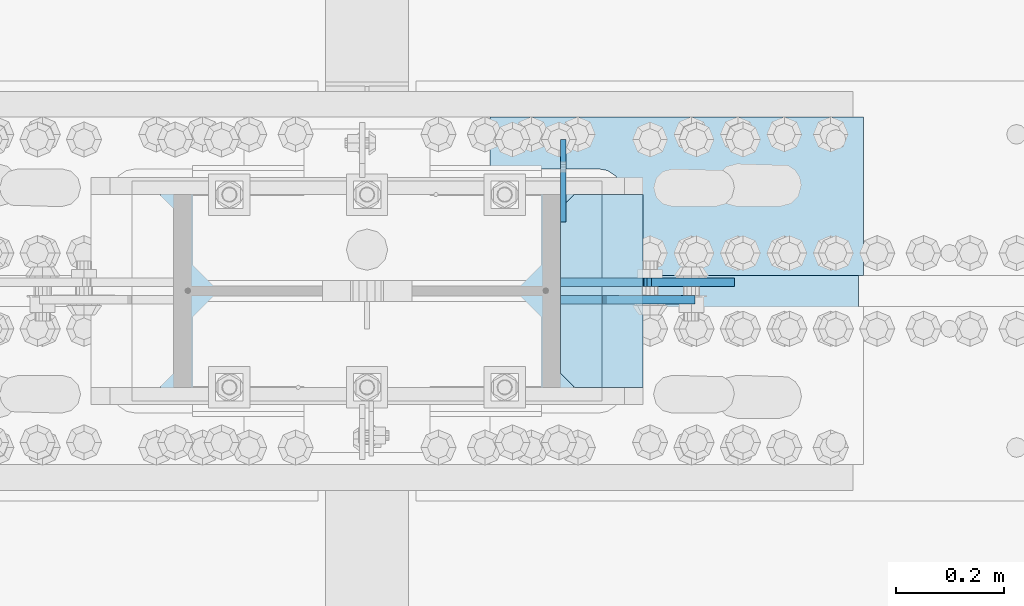
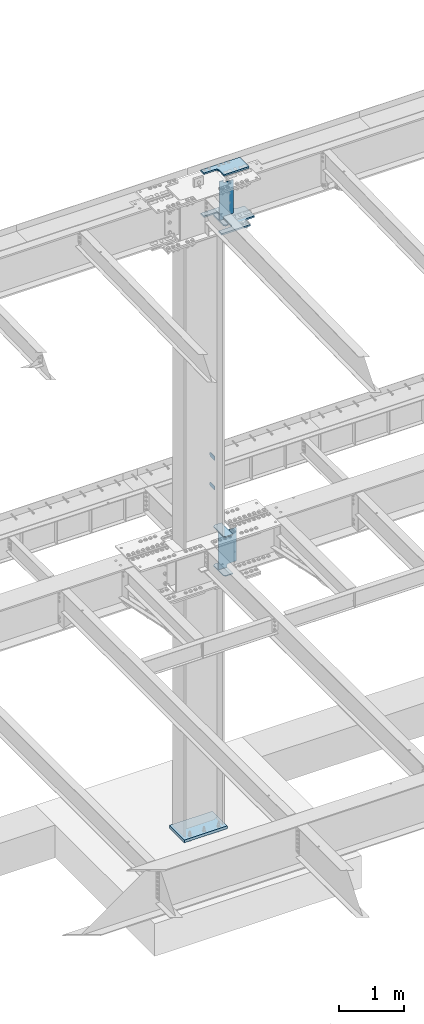
# One storey, part 1609 of 1763: 10 plates, 3 elements without a shape of their own.
"""IFC2X3 building model written with IfcOpenShell, lengths in millimetres."""

from ifc_helpers import new_model, si_unit, frame, origin_with_axes, place, context, subcontext, project, spatial, faceted_brep, material, type_object, element, aggregate, save


model = new_model("IFC2X3")

# Units and contexts
model_context = context("Model", 3, precision=1e-05, world=origin_with_axes())
body_context = subcontext(model_context, "Body", "Model", "MODEL_VIEW")
ifc_project = project(units=[si_unit("LENGTHUNIT", "METRE", prefix="MILLI"), si_unit("AREAUNIT", "SQUARE_METRE"), si_unit("VOLUMEUNIT", "CUBIC_METRE"), si_unit("MASSUNIT", "GRAM", prefix="KILO"), si_unit("TIMEUNIT", "SECOND"), si_unit("PLANEANGLEUNIT", "RADIAN"), si_unit("SOLIDANGLEUNIT", "STERADIAN"), si_unit("THERMODYNAMICTEMPERATUREUNIT", "DEGREE_CELSIUS"), si_unit("LUMINOUSINTENSITYUNIT", "LUMEN")], contexts=[model_context])

# Site, building, storey
site_placement = place(None, origin_with_axes())
site = spatial("IfcSite", under=ifc_project, at=site_placement, CompositionType="ELEMENT")
building_placement = place(site_placement, origin_with_axes())
building = spatial("IfcBuilding", under=site, at=building_placement, Name="Undefined", CompositionType="ELEMENT")
storey_placement = place(building_placement, origin_with_axes())
storey = spatial("IfcBuildingStorey", under=building, at=storey_placement, Name="Undefined", CompositionType="ELEMENT", Elevation=0.0)

# Assembly, plates
assembly_1_placement = place(storey_placement, origin_with_axes())
assembly_1 = element("IfcElementAssembly", 1, at=assembly_1_placement, inside=storey, Name="COLUMN", AssemblyPlace="NOTDEFINED", PredefinedType="RIGID_FRAME")
ifc_material_1 = material(Name="STEEL/A36")
plate_type_1 = type_object("IfcPlateType", PredefinedType="NOTDEFINED")
plate_1_placement = place(assembly_1_placement, frame((-72129.0872736984, 52247.8, 6489.69999847412), z_axis=(0.0, 0.0, -1.0), x_axis=(0.0, 1.0, 0.0)))
plate_1 = element("IfcPlate", 2, at=plate_1_placement, type_object=plate_type_1, material=ifc_material_1, Name="PLATE", context=body_context, shape_type="Brep", body=[
    faceted_brep([(0.0, -4.76249999999982, 0.0), (0.0, -4.76250000000073, 76.1999969482422), (0.0, 4.76250000000073, 76.1999969482422), (0.0, 4.76249999999982, 0.0), (114.299995422363, -4.76250000000073, 76.1999969482422), (114.299995422363, 4.76250000000073, 76.1999969482422), (126.073542436527, -4.76250000000073, 74.3352502937696), (126.073542436527, 4.76250000000073, 74.3352502937696), (136.694612637817, -4.76250000000073, 68.923544725345), (136.694612637817, 4.76250000000073, 68.923544725345), (145.123541673587, -4.76250000000073, 60.4946156895749), (145.123541673587, 4.76250000000073, 60.4946156895749), (150.535247242013, -4.76250000000073, 49.8735454882844), (150.535247242013, 4.76250000000073, 49.8735454882844), (152.399993896484, -4.76250000000073, 38.0999984741211), (152.399993896484, 4.76250000000073, 38.0999984741211), (150.535247242013, -4.76250000000073, 26.3264514599578), (150.535247242013, 4.76250000000073, 26.3264514599578), (145.123541673587, -4.76250000000073, 15.7053812586673), (145.123541673587, 4.76250000000073, 15.7053812586673), (136.694612637817, -4.76250000000073, 7.27645222289721), (136.694612637817, 4.76250000000073, 7.27645222289721), (126.073542436527, -4.76250000000073, 1.86474665447258), (126.073542436527, 4.76250000000073, 1.86474665447258), (114.299995422363, -4.76250000000073, 0.0), (114.299995422363, 4.76250000000073, 0.0)], [[[0, 1, 2, 3]], [[1, 4, 5, 2]], [[4, 6, 7, 5]], [[6, 8, 9, 7]], [[8, 10, 11, 9]], [[10, 12, 13, 11]], [[12, 14, 15, 13]], [[14, 16, 17, 15]], [[16, 18, 19, 17]], [[18, 20, 21, 19]], [[20, 22, 23, 21]], [[22, 24, 25, 23]], [[24, 0, 3, 25]], [[5, 7, 9, 11, 13, 15, 17, 19, 21, 23, 25, 3, 2]], [[24, 22, 20, 18, 16, 14, 12, 10, 8, 6, 4, 1, 0]]]),
])
plate_2_placement = place(assembly_1_placement, frame((-72129.0872736984, 52247.8, 5930.89999847412), z_axis=(0.0, 0.0, -1.0), x_axis=(0.0, 1.0, 0.0)))
plate_2 = element("IfcPlate", 3, at=plate_2_placement, type_object=plate_type_1, material=ifc_material_1, Name="PLATE", context=body_context, shape_type="Brep", body=[
    faceted_brep([(0.0, -4.76249999999982, 0.0), (0.0, -4.76250000000073, 76.1999969482422), (0.0, 4.76250000000073, 76.1999969482422), (0.0, 4.76249999999982, 0.0), (114.299995422363, -4.76250000000073, 76.1999969482422), (114.299995422363, 4.76250000000073, 76.1999969482422), (126.073542436527, -4.76250000000073, 74.3352502937696), (126.073542436527, 4.76250000000073, 74.3352502937696), (136.694612637817, -4.76250000000073, 68.923544725345), (136.694612637817, 4.76250000000073, 68.923544725345), (145.123541673587, -4.76250000000073, 60.4946156895749), (145.123541673587, 4.76250000000073, 60.4946156895749), (150.535247242013, -4.76250000000073, 49.8735454882844), (150.535247242013, 4.76250000000073, 49.8735454882844), (152.399993896484, -4.76250000000073, 38.0999984741211), (152.399993896484, 4.76250000000073, 38.0999984741211), (150.535247242013, -4.76250000000073, 26.3264514599578), (150.535247242013, 4.76250000000073, 26.3264514599578), (145.123541673587, -4.76250000000073, 15.7053812586673), (145.123541673587, 4.76250000000073, 15.7053812586673), (136.694612637817, -4.76250000000073, 7.27645222289721), (136.694612637817, 4.76250000000073, 7.27645222289721), (126.073542436527, -4.76250000000073, 1.86474665447258), (126.073542436527, 4.76250000000073, 1.86474665447258), (114.299995422363, -4.76250000000073, 0.0), (114.299995422363, 4.76250000000073, 0.0)], [[[0, 1, 2, 3]], [[1, 4, 5, 2]], [[4, 6, 7, 5]], [[6, 8, 9, 7]], [[8, 10, 11, 9]], [[10, 12, 13, 11]], [[12, 14, 15, 13]], [[14, 16, 17, 15]], [[16, 18, 19, 17]], [[18, 20, 21, 19]], [[20, 22, 23, 21]], [[22, 24, 25, 23]], [[24, 0, 3, 25]], [[5, 7, 9, 11, 13, 15, 17, 19, 21, 23, 25, 3, 2]], [[24, 22, 20, 18, 16, 14, 12, 10, 8, 6, 4, 1, 0]]]),
])
ifc_material_2 = material(Name="STEEL/A572-50")
plate_type_2 = type_object("IfcPlateType", PredefinedType="NOTDEFINED")
plate_3_placement = place(assembly_1_placement, frame((-71981.4497798019, 52298.6, 5157.7875), z_axis=(-1.0, 0.0, 0.0), x_axis=(0.0, -1.0, 0.0)))
plate_3 = element("IfcPlate", 4, at=plate_3_placement, type_object=plate_type_2, material=ifc_material_2, Name="PLATE", context=body_context, shape_type="Brep", body=[
    faceted_brep([(-7.27595761418343e-12, -7.9375, 0.0), (0.0, -7.9375, 126.999994277954), (0.0, 7.9375, 126.999994277954), (-7.27595761418343e-12, 7.9375, 0.0), (25.3999996185303, -7.9375, 152.399993896484), (25.3999996185303, 7.9375, 152.399993896484), (330.200006484985, -7.9375, 152.399993896484), (330.200006484985, 7.9375, 152.399993896484), (355.600006103516, -7.9375, 126.999994277954), (355.600006103516, 7.9375, 126.999994277954), (355.600006103516, -7.9375, 0.0), (355.600006103516, 7.9375, 0.0)], [[[0, 1, 2, 3]], [[1, 4, 5, 2]], [[4, 6, 7, 5]], [[6, 8, 9, 7]], [[8, 10, 11, 9]], [[10, 0, 3, 11]], [[5, 7, 9, 11, 3, 2]], [[10, 8, 6, 4, 1, 0]]]),
])
plate_4_placement = place(assembly_1_placement, frame((-71981.4497798019, 52298.6, 4427.5375), z_axis=(-1.0, 0.0, 0.0), x_axis=(0.0, -1.0, 0.0)))
plate_4 = element("IfcPlate", 5, at=plate_4_placement, type_object=plate_type_2, material=ifc_material_2, Name="PLATE", context=body_context, shape_type="Brep", body=[
    faceted_brep([(-7.27595761418343e-12, -7.9375, 0.0), (0.0, -7.9375, 126.999994277954), (0.0, 7.9375, 126.999994277954), (-7.27595761418343e-12, 7.9375, 0.0), (25.3999996185303, -7.9375, 152.399993896484), (25.3999996185303, 7.9375, 152.399993896484), (330.200006484985, -7.9375, 152.399993896484), (330.200006484985, 7.9375, 152.399993896484), (355.600006103516, -7.9375, 126.999994277954), (355.600006103516, 7.9375, 126.999994277954), (355.600006103516, -7.9375, 0.0), (355.600006103516, 7.9375, 0.0)], [[[0, 1, 2, 3]], [[1, 4, 5, 2]], [[4, 6, 7, 5]], [[6, 8, 9, 7]], [[8, 10, 11, 9]], [[10, 0, 3, 11]], [[5, 7, 9, 11, 3, 2]], [[10, 8, 6, 4, 1, 0]]]),
])

# Assembly, plate
assembly_2_placement = place(storey_placement, origin_with_axes())
assembly_2 = element("IfcElementAssembly", 6, at=assembly_2_placement, inside=storey, Name="PLATE", AssemblyPlace="NOTDEFINED", PredefinedType="RIGID_FRAME")
plate_type_3 = type_object("IfcPlateType", PredefinedType="NOTDEFINED")
plate_5_placement = place(assembly_2_placement, frame((-72264.0247736983, 51800.1250002128, 10955.3374917654), z_axis=(0.0, 1.0, 0.0), x_axis=(1.0, 0.0, 0.0)))
plate_5 = element("IfcPlate", 7, at=plate_5_placement, type_object=plate_type_3, material=ifc_material_2, Name="PLATE", context=body_context, shape_type="Brep", body=[
    faceted_brep([(0.0, -14.2875000000058, 0.0), (0.0, -14.2875000000004, 95.25), (0.0, 14.2875000000004, 95.25), (0.0, 14.2875000000058, 0.0), (209.550006866455, -14.2875000000004, 95.25), (209.550006866455, 14.2875000000004, 95.25), (220.342425159237, -14.2875000000004, 96.9593511310522), (220.342425159237, 14.2875000000004, 96.9593511310522), (230.078406354325, -14.2875000000004, 101.920081325748), (230.078406354325, 14.2875000000004, 101.920081325748), (237.804924777767, -14.2875000000004, 109.646599749191), (237.804924777767, 14.2875000000004, 109.646599749191), (242.765654972463, -14.2875000000004, 119.382580944279), (242.765654972463, 14.2875000000004, 119.382580944279), (244.475006103516, -14.2875000000004, 130.174999237061), (244.475006103516, 14.2875000000004, 130.174999237061), (244.475006103516, -14.2875000000004, 511.174976348877), (244.475006103516, 14.2875000000004, 511.174976348877), (242.765654972463, -14.2875000000004, 521.967394641659), (242.765654972463, 14.2875000000004, 521.967394641659), (237.804924777767, -14.2875000000004, 531.703375836747), (237.804924777767, 14.2875000000004, 531.703375836747), (230.078406354325, -14.2875000000004, 539.429894260189), (230.078406354325, 14.2875000000004, 539.429894260189), (220.342425159237, -14.2875000000004, 544.390624454885), (220.342425159237, 14.2875000000004, 544.390624454885), (209.550006866455, -14.2875000000004, 546.099975585938), (209.550006866455, 14.2875000000004, 546.099975585938), (0.0, -14.2875000000004, 546.099975585938), (0.0, 14.2875000000004, 546.099975585938), (0.0, -14.2875000000004, 641.349975585938), (0.0, 14.2875000000004, 641.349975585938), (508.0, -14.2875000000004, 641.349975585938), (508.0, 14.2875000000004, 641.349975585938), (508.0, -14.2875000000004, 511.174999237061), (508.0, 14.2875000000004, 511.174999237061), (509.709351131052, -14.2875000000004, 500.382580944279), (509.709351131052, 14.2875000000004, 500.382580944279), (514.670081325748, -14.2875000000004, 490.646599749191), (514.670081325748, 14.2875000000004, 490.646599749191), (522.396599749191, -14.2875000000004, 482.920081325748), (522.396599749191, 14.2875000000004, 482.920081325748), (532.132580944279, -14.2875000000004, 477.959351131052), (532.132580944279, 14.2875000000004, 477.959351131052), (542.924999237061, -14.2875000000004, 476.25), (542.924999237061, 14.2875000000004, 476.25), (679.450012207031, -14.2875000000004, 476.25), (679.450012207031, 14.2875000000004, 476.25), (679.450012207031, -14.2875000000004, 165.100006103516), (679.450012207031, 14.2875000000004, 165.100006103516), (542.924999237061, -14.2875000000004, 165.100006103516), (542.924999237061, 14.2875000000004, 165.100006103516), (532.132580944279, -14.2875000000004, 163.390654972463), (532.132580944279, 14.2875000000004, 163.390654972463), (522.396599749191, -14.2875000000004, 158.429924777767), (522.396599749191, 14.2875000000004, 158.429924777767), (514.670081325748, -14.2875000000004, 150.703406354325), (514.670081325748, 14.2875000000004, 150.703406354325), (509.709351131052, -14.2875000000004, 140.967425159237), (509.709351131052, 14.2875000000004, 140.967425159237), (508.0, -14.2875000000004, 130.175006866455), (508.0, 14.2875000000004, 130.175006866455), (508.0, -14.2875000000004, 0.0), (508.0, 14.2875000000004, 0.0)], [[[0, 1, 2, 3]], [[1, 4, 5, 2]], [[4, 6, 7, 5]], [[6, 8, 9, 7]], [[8, 10, 11, 9]], [[10, 12, 13, 11]], [[12, 14, 15, 13]], [[14, 16, 17, 15]], [[16, 18, 19, 17]], [[18, 20, 21, 19]], [[20, 22, 23, 21]], [[22, 24, 25, 23]], [[24, 26, 27, 25]], [[26, 28, 29, 27]], [[28, 30, 31, 29]], [[30, 32, 33, 31]], [[32, 34, 35, 33]], [[34, 36, 37, 35]], [[36, 38, 39, 37]], [[38, 40, 41, 39]], [[40, 42, 43, 41]], [[42, 44, 45, 43]], [[44, 46, 47, 45]], [[46, 48, 49, 47]], [[48, 50, 51, 49]], [[50, 52, 53, 51]], [[52, 54, 55, 53]], [[54, 56, 57, 55]], [[56, 58, 59, 57]], [[58, 60, 61, 59]], [[60, 62, 63, 61]], [[62, 0, 3, 63]], [[5, 7, 9, 11, 13, 15, 17, 19, 21, 23, 25, 27, 29, 31, 33, 35, 37, 39, 41, 43, 45, 47, 49, 51, 53, 55, 57, 59, 61, 63, 3, 2]], [[62, 60, 58, 56, 54, 52, 50, 48, 46, 44, 42, 40, 38, 36, 34, 32, 30, 28, 26, 24, 22, 20, 18, 16, 14, 12, 10, 8, 6, 4, 1, 0]]]),
])
aggregate(assembly_2, [plate_5])

assembly_3_placement = place(storey_placement, origin_with_axes())
assembly_3 = element("IfcElementAssembly", 8, at=assembly_3_placement, inside=storey, Name="TOP PLATE", AssemblyPlace="NOTDEFINED", PredefinedType="RIGID_FRAME")
plate_type_4 = type_object("IfcPlateType", PredefinedType="NOTDEFINED")
plate_6_placement = place(assembly_3_placement, frame((-72019.5497736984, 52149.3750002128, 11761.7874917654), z_axis=(0.0, 1.0, 0.0), x_axis=(1.0, 0.0, 0.0)))
plate_6 = element("IfcPlate", 9, at=plate_6_placement, type_object=plate_type_4, material=ifc_material_2, Name="TOP PLATE", context=body_context, shape_type="Brep", body=[
    faceted_brep([(0.0, -14.2875000000058, 0.0), (0.0, -14.2875000000004, 152.400001525879), (0.0, 14.2875000000004, 152.400001525879), (0.0, 14.2875000000058, 0.0), (-3.38355483795021, -14.2875000000004, 169.410284201171), (-3.38355483795021, 14.2875000000004, 169.410284201171), (-13.0191037997211, -14.2875000000004, 183.830902303795), (-13.0191037997211, 14.2875000000004, 183.830902303795), (-27.4397219023449, -14.2875000000004, 193.466451265565), (-27.4397219023449, 14.2875000000004, 193.466451265565), (-44.4500007629395, -14.2875000000004, 196.850006103516), (-44.4500007629395, 14.2875000000004, 196.850006103516), (-244.475006103516, -14.2875000000004, 196.850006103516), (-244.475006103516, 14.2875000000004, 196.850006103516), (-244.475006103516, -14.2875000000004, 292.100006103516), (-244.475006103516, 14.2875000000004, 292.100006103516), (444.5, -14.2875000000004, 292.100006103516), (444.5, 14.2875000000004, 292.100006103516), (444.5, -14.2875000000004, 0.0), (444.5, 14.2875000000004, 0.0)], [[[0, 1, 2, 3]], [[1, 4, 5, 2]], [[4, 6, 7, 5]], [[6, 8, 9, 7]], [[8, 10, 11, 9]], [[10, 12, 13, 11]], [[12, 14, 15, 13]], [[14, 16, 17, 15]], [[16, 18, 19, 17]], [[18, 0, 3, 19]], [[5, 7, 9, 11, 13, 15, 17, 19, 3, 2]], [[18, 16, 14, 12, 10, 8, 6, 4, 1, 0]]]),
])
aggregate(assembly_3, [plate_6])

# Plate
plate_type_5 = type_object("IfcPlateType", PredefinedType="NOTDEFINED")
plate_7_placement = place(assembly_1_placement, frame((-72133.8497736984, 52298.6, 10980.7374917654), z_axis=(1.0, 0.0, 0.0), x_axis=(0.0, -1.0, 0.0)))
plate_7 = element("IfcPlate", 10, at=plate_7_placement, type_object=plate_type_5, material=ifc_material_2, Name="BRIDGE PLATE", context=body_context, shape_type="Brep", body=[
    faceted_brep([(0.0, -11.1124999999993, 25.3999996185303), (0.0, -11.1124999999993, 76.1999969482422), (0.0, 11.1124999999993, 76.1999969482422), (0.0, 11.1124999999993, 25.3999996185303), (355.600006103516, -11.1124999999993, 76.1999969482422), (355.600006103516, 11.1124999999993, 76.1999969482422), (355.600006103516, -11.1124999999993, 25.3999996185303), (355.600006103516, 11.1124999999993, 25.3999996185303), (330.200006484985, -11.1124999999993, 0.0), (330.200006484985, 11.1124999999993, 0.0), (25.3999996185303, -11.1124999999993, 0.0), (25.3999996185303, 11.1124999999993, 0.0)], [[[0, 1, 2, 3]], [[1, 4, 5, 2]], [[4, 6, 7, 5]], [[6, 8, 9, 7]], [[8, 10, 11, 9]], [[10, 0, 3, 11]], [[5, 7, 9, 11, 3, 2]], [[10, 8, 6, 4, 1, 0]]]),
])

plate_type_6 = type_object("IfcPlateType", PredefinedType="NOTDEFINED")
plate_8_placement = place(assembly_1_placement, frame((-71886.1997736983, 52104.9250002128, 11045.8249917654), z_axis=(-1.0, 0.0, 0.0), x_axis=(0.0, 0.0, 1.0)))
plate_8 = element("IfcPlate", 11, at=plate_8_placement, type_object=plate_type_6, material=ifc_material_2, Name="SHEAR TAB", context=body_context, shape_type="Brep", body=[
    faceted_brep([(-7.27595761418343e-12, -7.9375, 0.0), (0.0, -7.9375, 158.749997138977), (0.0, 7.9375, 158.749997138977), (-7.27595761418343e-12, 7.9375, 0.0), (-0.966729922587547, -7.9375, 163.610076657023), (-0.966729922587547, 7.9375, 163.610076657023), (-3.71974382306507, -7.9375, 167.730253125177), (-3.71974382306507, 7.9375, 167.730253125177), (-7.83992029121873, -7.9375, 170.483267025651), (-7.83992029121873, 7.9375, 170.483267025651), (-12.6999998092651, -7.9375, 171.449996948242), (-12.6999998092651, 7.9375, 171.449996948242), (-53.9749984741211, -7.9375, 171.449996948242), (-53.9749984741211, 7.9375, 171.449996948242), (-53.9749984741211, -7.9375, 247.649993896484), (-53.9749984741211, 7.9375, 247.649993896484), (671.512451171875, -7.9375, 247.649993896484), (671.512451171875, 7.9375, 247.649993896484), (671.512451171875, -7.9375, 171.449996948242), (671.512451171875, 7.9375, 171.449996948242), (638.174975395203, -7.9375, 171.449996948242), (638.174975395203, 7.9375, 171.449996948242), (633.314895877156, -7.9375, 170.483267025651), (633.314895877156, 7.9375, 170.483267025651), (629.194719409003, -7.9375, 167.730253125177), (629.194719409003, 7.9375, 167.730253125177), (626.441705508525, -7.9375, 163.610076657023), (626.441705508525, 7.9375, 163.610076657023), (625.474975585938, -7.9375, 158.749997138977), (625.474975585938, 7.9375, 158.749997138977), (625.474975585938, -7.9375, 0.0), (625.474975585938, 7.9375, 0.0)], [[[0, 1, 2, 3]], [[1, 4, 5, 2]], [[4, 6, 7, 5]], [[6, 8, 9, 7]], [[8, 10, 11, 9]], [[10, 12, 13, 11]], [[12, 14, 15, 13]], [[14, 16, 17, 15]], [[16, 18, 19, 17]], [[18, 20, 21, 19]], [[20, 22, 23, 21]], [[22, 24, 25, 23]], [[24, 26, 27, 25]], [[26, 28, 29, 27]], [[28, 30, 31, 29]], [[30, 0, 3, 31]], [[5, 7, 9, 11, 13, 15, 17, 19, 21, 23, 25, 27, 29, 31, 3, 2]], [[30, 28, 26, 24, 22, 20, 18, 16, 14, 12, 10, 8, 6, 4, 1, 0]]]),
])

plate_type_7 = type_object("IfcPlateType", PredefinedType="NOTDEFINED")
plate_9_placement = place(assembly_1_placement, frame((-71813.1747736984, 52136.675, 4435.47562255859), z_axis=(-1.0, 0.0, 0.0), x_axis=(0.0, 0.0, 1.0)))
plate_9 = element("IfcPlate", 12, at=plate_9_placement, type_object=plate_type_7, material=ifc_material_2, Name="SHEAR TAB", context=body_context, shape_type="Brep", body=[
    faceted_brep([(684.212475585938, -7.9375, 0.0), (684.212475585938, 7.9375, 0.0), (684.212475585938, 7.9375, 142.875009536743), (684.212475585938, -7.9375, 142.875009536743), (686.145935431114, 7.9375, 152.595168572821), (686.145935431114, -7.9375, 152.595168572821), (691.65196323207, 7.9375, 160.835521509129), (691.65196323207, -7.9375, 160.835521509129), (699.892316168377, 7.9375, 166.341549310091), (699.892316168377, -7.9375, 166.341549310091), (709.612475204468, 7.9375, 168.275009155273), (709.612475204468, -7.9375, 168.275009155273), (712.787475585938, -7.9375, 168.275009155273), (712.787475585938, 7.9375, 168.275009155273), (58.7375022888209, -7.9375, 142.875012588498), (58.7375022888209, 7.9375, 142.875012588498), (58.7375022888209, 7.9375, 0.0), (58.7375022888209, -7.9375, 0.0), (56.8040424436449, -7.9375, 152.595171624591), (56.8040424436449, 7.9375, 152.595171624591), (51.2980146426889, -7.9375, 160.835524560898), (51.2980146426889, 7.9375, 160.835524560898), (43.0576617063816, -7.9375, 166.341552361846), (43.0576617063816, 7.9375, 166.341552361846), (33.3375026702906, -7.9375, 168.275012207028), (33.3375026702906, 7.9375, 168.275012207028), (0.0, -7.9375, 168.275012207028), (0.0, 7.9375, 168.275012207028), (0.0, -7.9375, 320.674987792969), (0.0, 7.9375, 320.674987792969), (712.787475585938, -7.9375, 320.674987792969), (712.787475585938, 7.9375, 320.674987792969)], [[[0, 1, 2, 3]], [[3, 2, 4, 5]], [[5, 4, 6, 7]], [[7, 6, 8, 9]], [[9, 8, 10, 11]], [[12, 11, 10, 13]], [[14, 15, 16, 17]], [[18, 19, 15, 14]], [[20, 21, 19, 18]], [[22, 23, 21, 20]], [[24, 25, 23, 22]], [[26, 27, 25, 24]], [[28, 29, 27, 26]], [[28, 30, 31, 29]], [[31, 30, 12, 13]], [[8, 6, 4, 2, 1, 16, 15, 19, 21, 23, 25, 27, 29, 31, 13, 10]], [[17, 16, 1, 0]], [[30, 28, 26, 24, 22, 20, 18, 14, 17, 0, 3, 5, 7, 9, 11, 12]]]),
])

plate_type_8 = type_object("IfcPlateType", PredefinedType="NOTDEFINED")
plate_10_placement = place(assembly_1_placement, frame((-72872.0372736984, 51892.2, -241.299999999999), z_axis=(0.0, 1.0, 0.0), x_axis=(1.0, 0.0, 0.0)))
plate_10 = element("IfcPlate", 13, at=plate_10_placement, type_object=plate_type_8, material=ifc_material_1, Name="PLATE", context=body_context, shape_type="Brep", body=[
    faceted_brep([(0.0, -25.4000000000015, 0.0), (0.0, -25.4, 457.200012207031), (0.0, 25.4, 457.200012207031), (0.0, 25.4000000000015, 0.0), (762.0, -25.4, 457.200012207031), (762.0, 25.4, 457.200012207031), (762.0, -25.4, 0.0), (762.0, 25.4, 0.0)], [[[0, 1, 2, 3]], [[1, 4, 5, 2]], [[4, 6, 7, 5]], [[6, 0, 3, 7]], [[5, 7, 3, 2]], [[6, 4, 1, 0]]]),
])

aggregate(assembly_1, [plate_1, plate_2, plate_3, plate_4, plate_8, plate_7, plate_9, plate_10])

save(model, "model.ifc")
